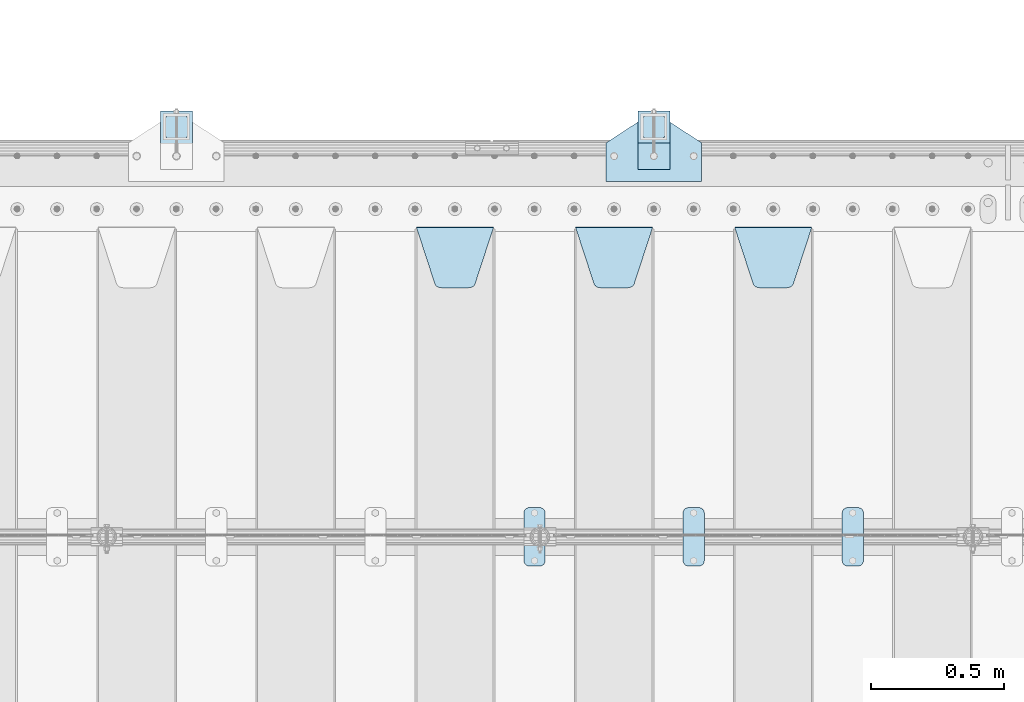
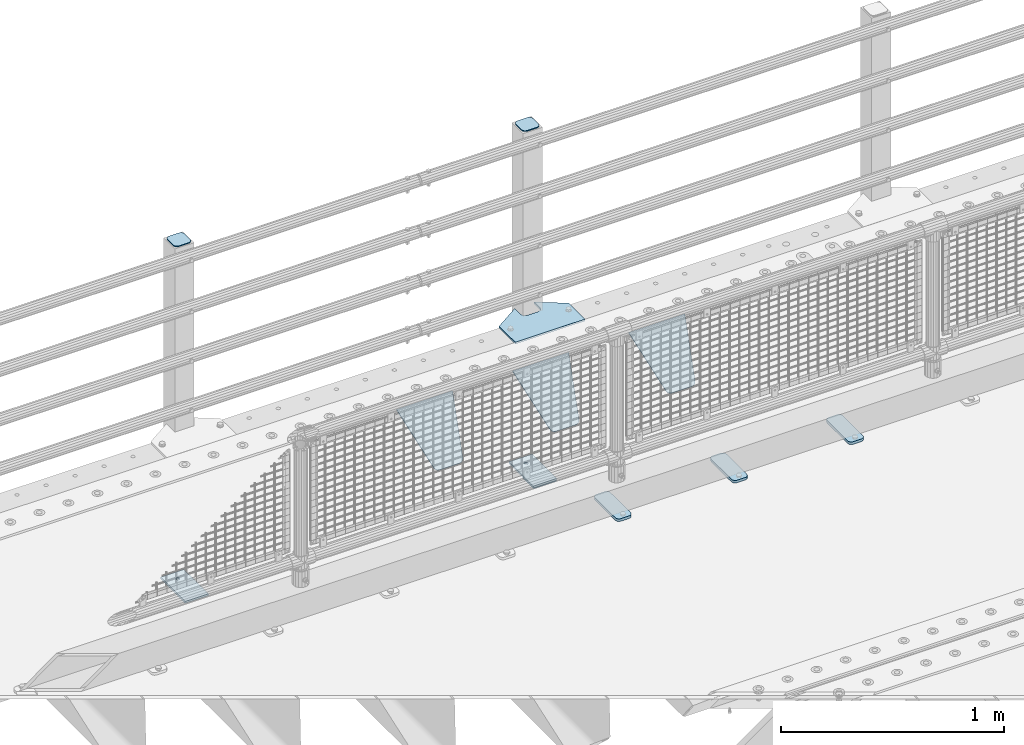
# One storey, part 233 of 270: 12 plates.
"""IFC2X3 building model written with IfcOpenShell, lengths in millimetres."""

from ifc_helpers import new_model, si_unit, frame, origin_with_axes, place, context, subcontext, project, spatial, faceted_brep, material, type_object, element, save


model = new_model("IFC2X3")

# Units and contexts
model_context = context("Model", 3, precision=1e-05, world=origin_with_axes())
body_context = subcontext(model_context, "Body", "Model", "MODEL_VIEW")
ifc_project = project(units=[si_unit("LENGTHUNIT", "METRE", prefix="MILLI"), si_unit("AREAUNIT", "SQUARE_METRE"), si_unit("VOLUMEUNIT", "CUBIC_METRE"), si_unit("MASSUNIT", "GRAM", prefix="KILO"), si_unit("TIMEUNIT", "SECOND"), si_unit("PLANEANGLEUNIT", "RADIAN"), si_unit("SOLIDANGLEUNIT", "STERADIAN"), si_unit("THERMODYNAMICTEMPERATUREUNIT", "DEGREE_CELSIUS"), si_unit("LUMINOUSINTENSITYUNIT", "LUMEN")], contexts=[model_context])

# Site, building, storey
site_placement = place(None, origin_with_axes())
site = spatial("IfcSite", under=ifc_project, at=site_placement, CompositionType="ELEMENT")
building_placement = place(site_placement, origin_with_axes())
building = spatial("IfcBuilding", under=site, at=building_placement, Name="Standard", CompositionType="ELEMENT")
storey_placement = place(building_placement, origin_with_axes())
storey = spatial("IfcBuildingStorey", under=building, at=storey_placement, Name="Undefined", CompositionType="ELEMENT", Elevation=0.0)

# Plates
ifc_material_1 = material(Name="STEEL/S355J2")
plate_type_1 = type_object("IfcPlateType", PredefinedType="NOTDEFINED")
plate_1_placement = place(storey_placement, frame((5770.0, -14995.0, 5.00000000004911), z_axis=(0.0, 1.0, 0.0), x_axis=(1.0, 0.0, 0.0)))
element("IfcPlate", 1, at=plate_1_placement, inside=storey, type_object=plate_type_1, material=ifc_material_1, context=body_context, shape_type="Brep", body=[
    faceted_brep([(0.0, -5.0, 0.0), (2.31396552408114e-06, -5.0, 145.0), (2.31396552408114e-06, 5.0, 145.0), (0.0, 5.0, 0.0), (130.0, -5.0, 230.0), (130.0, 5.0, 230.0), (130.0, -5.0, 180.0), (130.0, 5.0, 180.0), (130.48036798992, -5.0, 175.122741949597), (130.48036798992, 5.0, 175.122741949597), (131.903011687216, -5.0, 170.432914190873), (131.903011687216, 5.0, 170.432914190873), (134.213259692435, -5.0, 166.11074417451), (134.213259692435, 5.0, 166.11074417451), (137.322330470335, -5.0, 162.322330470337), (137.322330470335, 5.0, 162.322330470337), (141.110744174512, -5.0, 159.213259692437), (141.110744174512, 5.0, 159.213259692437), (145.432914190871, -5.0, 156.903011687218), (145.432914190871, 5.0, 156.903011687218), (150.122741949595, -5.0, 155.48036798992), (150.122741949595, 5.0, 155.48036798992), (155.0, -5.0, 155.0), (155.0, 5.0, 155.0), (205.0, -5.0, 155.0), (205.0, 5.0, 155.0), (209.877258050405, -5.0, 155.48036798992), (209.877258050405, 5.0, 155.48036798992), (214.567085809129, -5.0, 156.903011687218), (214.567085809129, 5.0, 156.903011687218), (218.889255825488, -5.0, 159.213259692437), (218.889255825488, 5.0, 159.213259692437), (222.677669529665, -5.0, 162.322330470337), (222.677669529665, 5.0, 162.322330470337), (225.786740307565, -5.0, 166.11074417451), (225.786740307565, 5.0, 166.11074417451), (228.096988312784, -5.0, 170.432914190873), (228.096988312784, 5.0, 170.432914190873), (229.51963201008, -5.0, 175.122741949597), (229.51963201008, 5.0, 175.122741949597), (230.0, -5.0, 180.0), (230.0, 5.0, 180.0), (230.0, -5.0, 230.0), (230.0, 5.0, 230.0), (360.0, -5.0, 145.0), (360.0, 5.0, 145.0), (360.0, -5.0, -7.27595761418343e-12), (360.0, 5.0, -7.27595761418343e-12)], [[[0, 1, 2, 3]], [[1, 4, 5, 2]], [[4, 6, 7, 5]], [[6, 8, 9, 7]], [[8, 10, 11, 9]], [[10, 12, 13, 11]], [[12, 14, 15, 13]], [[14, 16, 17, 15]], [[16, 18, 19, 17]], [[18, 20, 21, 19]], [[20, 22, 23, 21]], [[22, 24, 25, 23]], [[24, 26, 27, 25]], [[26, 28, 29, 27]], [[28, 30, 31, 29]], [[30, 32, 33, 31]], [[32, 34, 35, 33]], [[34, 36, 37, 35]], [[36, 38, 39, 37]], [[38, 40, 41, 39]], [[40, 42, 43, 41]], [[42, 44, 45, 43]], [[44, 46, 47, 45]], [[46, 0, 3, 47]], [[5, 7, 9, 11, 13, 15, 17, 19, 21, 23, 25, 27, 29, 31, 33, 35, 37, 39, 41, 43, 45, 47, 3, 2]], [[46, 44, 42, 40, 38, 36, 34, 32, 30, 28, 26, 24, 22, 20, 18, 16, 14, 12, 10, 8, 6, 4, 1, 0]]]),
])
plate_type_2 = type_object("IfcPlateType", PredefinedType="NOTDEFINED")
for number, where, z_axis, x_axis in (
    (2, (5890.00000000014, -14949.9999999998, -850.000000000002), (0.0, 1.0, 0.0), (1.0, 0.0, 0.0)),
    (3, (4090.00000000014, -14949.9999999998, -850.000000000002), (0.0, 1.0, 0.0), (1.0, 0.0, 0.0)),
):
    element("IfcPlate", number, at=place(storey_placement, frame(where, z_axis=z_axis, x_axis=x_axis)), inside=storey, type_object=plate_type_2, material=ifc_material_1, context=body_context, shape_type="Brep", body=[
        faceted_brep([(66.3639610305399, -5.0, 163.636038969114), (66.3639610305399, 5.0, 163.636038969114), (59.9999999998618, 5.0, 160.999999999793), (59.9999999998618, -5.0, 160.999999999793), (53.6360389691836, 5.0, 163.636038969114), (53.6360389691836, -5.0, 163.636038969114), (50.9999999998618, 5.0, 169.999999999793), (50.9999999998618, -5.0, 169.999999999793), (53.6360389691836, 5.0, 176.363961030471), (53.6360389691836, -5.0, 176.363961030471), (59.9999999998618, 5.0, 178.999999999793), (59.9999999998618, -5.0, 178.999999999793), (66.3639610305399, 5.0, 176.363961030471), (66.3639610305399, -5.0, 176.363961030471), (68.9999999998618, 5.0, 169.999999999793), (68.9999999998618, -5.0, 169.999999999793), (120.0, -5.0, 0.0), (120.0, -5.0, 220.0), (0.0, -5.0, 220.0), (0.0, -5.0, 0.0), (0.0, 5.0, 0.0), (120.0, 5.0, 0.0), (120.0, 5.0, 220.0), (0.0, 5.0, 220.0)], [[[0, 1, 2, 3]], [[3, 2, 4, 5]], [[5, 4, 6, 7]], [[7, 6, 8, 9]], [[9, 8, 10, 11]], [[11, 10, 12, 13]], [[13, 12, 14, 15]], [[15, 14, 1, 0]], [[16, 17, 18, 19], [3, 5, 7, 9, 11, 13, 15, 0]], [[16, 19, 20, 21]], [[17, 16, 21, 22]], [[18, 17, 22, 23]], [[19, 18, 23, 20]], [[22, 21, 20, 23], [10, 8, 6, 4, 2, 1, 14, 12]]]),
    ])
plate_type_3 = type_object("IfcPlateType", PredefinedType="NOTDEFINED")
plate_2_placement = place(storey_placement, frame((5994.00000000013, -14833.9999999998, 1012.50000000001), z_axis=(0.0, 1.0, 0.0), x_axis=(-1.0, 0.0, 0.0)))
element("IfcPlate", 4, at=plate_2_placement, inside=storey, type_object=plate_type_3, material=ifc_material_1, context=body_context, shape_type="Brep", body=[
    faceted_brep([(0.0, -2.5, 19.0), (0.0, -2.5, 69.0), (0.0, 2.5, 69.0), (0.0, 2.5, 19.0), (0.476369668544066, -2.5, 73.2278977451697), (0.476369668544066, 2.5, 73.2278977451697), (1.88159150985302, -2.5, 77.2437910432327), (1.88159150985302, 2.5, 77.2437910432327), (4.14520183310742, -2.5, 80.8463062353167), (4.14520183310742, 2.5, 80.8463062353167), (7.15369376468516, -2.5, 83.8547981668926), (7.15369376468516, 2.5, 83.8547981668926), (10.7562089567655, -2.5, 86.1184084901452), (10.7562089567655, 2.5, 86.1184084901452), (14.7721022548285, -2.5, 87.5236303314541), (14.7721022548285, 2.5, 87.5236303314541), (19.0, -2.5, 88.0), (19.0, 2.5, 88.0), (69.0, -2.5, 88.0), (69.0, 2.5, 88.0), (73.2278977451715, -2.5, 87.5236303314541), (73.2278977451715, 2.5, 87.5236303314541), (77.2437910432345, -2.5, 86.1184084901452), (77.2437910432345, 2.5, 86.1184084901452), (80.8463062353148, -2.5, 83.8547981668926), (80.8463062353148, 2.5, 83.8547981668926), (83.8547981668926, -2.5, 80.8463062353167), (83.8547981668926, 2.5, 80.8463062353167), (86.118408490147, -2.5, 77.2437910432345), (86.118408490147, 2.5, 77.2437910432345), (87.5236303314559, -2.5, 73.2278977451697), (87.5236303314559, 2.5, 73.2278977451697), (88.0, -2.5, 69.0), (88.0, 2.5, 69.0), (88.0, -2.5, 19.0), (88.0, 2.5, 19.0), (87.5236303314559, -2.5, 14.7721022548303), (87.5236303314559, 2.5, 14.7721022548303), (86.118408490147, -2.5, 10.7562089567673), (86.118408490147, 2.5, 10.7562089567673), (83.8547981668926, -2.5, 7.15369376468334), (83.8547981668926, 2.5, 7.15369376468334), (80.8463062353148, -2.5, 4.14520183310742), (80.8463062353148, 2.5, 4.14520183310742), (77.2437910432345, -2.5, 1.88159150985484), (77.2437910432345, 2.5, 1.88159150985484), (73.2278977451715, -2.5, 0.476369668545885), (73.2278977451715, 2.5, 0.476369668545885), (69.0, -2.5, 0.0), (69.0, 2.5, 0.0), (19.0, -2.5, 0.0), (19.0, 2.5, 0.0), (14.7721022548285, -2.5, 0.476369668545885), (14.7721022548285, 2.5, 0.476369668545885), (10.7562089567655, -2.5, 1.88159150985484), (10.7562089567655, 2.5, 1.88159150985484), (7.15369376468516, -2.5, 4.14520183310742), (7.15369376468516, 2.5, 4.14520183310742), (4.14520183310742, -2.5, 7.15369376468334), (4.14520183310742, 2.5, 7.15369376468334), (1.88159150985302, -2.5, 10.7562089567673), (1.88159150985302, 2.5, 10.7562089567673), (0.476369668544066, -2.5, 14.7721022548303), (0.476369668544066, 2.5, 14.7721022548303)], [[[0, 1, 2, 3]], [[1, 4, 5, 2]], [[4, 6, 7, 5]], [[6, 8, 9, 7]], [[8, 10, 11, 9]], [[10, 12, 13, 11]], [[12, 14, 15, 13]], [[14, 16, 17, 15]], [[16, 18, 19, 17]], [[18, 20, 21, 19]], [[20, 22, 23, 21]], [[22, 24, 25, 23]], [[24, 26, 27, 25]], [[26, 28, 29, 27]], [[28, 30, 31, 29]], [[30, 32, 33, 31]], [[32, 34, 35, 33]], [[34, 36, 37, 35]], [[36, 38, 39, 37]], [[38, 40, 41, 39]], [[40, 42, 43, 41]], [[42, 44, 45, 43]], [[44, 46, 47, 45]], [[46, 48, 49, 47]], [[48, 50, 51, 49]], [[50, 52, 53, 51]], [[52, 54, 55, 53]], [[54, 56, 57, 55]], [[56, 58, 59, 57]], [[58, 60, 61, 59]], [[60, 62, 63, 61]], [[62, 0, 3, 63]], [[5, 7, 9, 11, 13, 15, 17, 19, 21, 23, 25, 27, 29, 31, 33, 35, 37, 39, 41, 43, 45, 47, 49, 51, 53, 55, 57, 59, 61, 63, 3, 2]], [[62, 60, 58, 56, 54, 52, 50, 48, 46, 44, 42, 40, 38, 36, 34, 32, 30, 28, 26, 24, 22, 20, 18, 16, 14, 12, 10, 8, 6, 4, 1, 0]]]),
])
plate_3_placement = place(storey_placement, frame((4194.00000000013, -14833.9999999998, 1012.50000000001), z_axis=(0.0, 1.0, 0.0), x_axis=(-1.0, 0.0, 0.0)))
element("IfcPlate", 5, at=plate_3_placement, inside=storey, type_object=plate_type_3, material=ifc_material_1, context=body_context, shape_type="Brep", body=[
    faceted_brep([(0.0, -2.5, 19.0), (0.0, -2.5, 69.0), (0.0, 2.5, 69.0), (0.0, 2.5, 19.0), (0.476369668544066, -2.5, 73.2278977451697), (0.476369668544066, 2.5, 73.2278977451697), (1.88159150985302, -2.5, 77.2437910432327), (1.88159150985302, 2.5, 77.2437910432327), (4.14520183310742, -2.5, 80.8463062353167), (4.14520183310742, 2.5, 80.8463062353167), (7.15369376468516, -2.5, 83.8547981668926), (7.15369376468516, 2.5, 83.8547981668926), (10.7562089567655, -2.5, 86.1184084901452), (10.7562089567655, 2.5, 86.1184084901452), (14.7721022548285, -2.5, 87.5236303314541), (14.7721022548285, 2.5, 87.5236303314541), (19.0, -2.5, 88.0), (19.0, 2.5, 88.0), (69.0, -2.5, 88.0), (69.0, 2.5, 88.0), (73.2278977451715, -2.5, 87.5236303314541), (73.2278977451715, 2.5, 87.5236303314541), (77.2437910432345, -2.5, 86.1184084901452), (77.2437910432345, 2.5, 86.1184084901452), (80.8463062353148, -2.5, 83.8547981668926), (80.8463062353148, 2.5, 83.8547981668926), (83.8547981668926, -2.5, 80.8463062353167), (83.8547981668926, 2.5, 80.8463062353167), (86.118408490147, -2.5, 77.2437910432345), (86.118408490147, 2.5, 77.2437910432345), (87.5236303314559, -2.5, 73.2278977451697), (87.5236303314559, 2.5, 73.2278977451697), (88.0, -2.5, 69.0), (88.0, 2.5, 69.0), (88.0, -2.5, 19.0), (88.0, 2.5, 19.0), (87.5236303314559, -2.5, 14.7721022548303), (87.5236303314559, 2.5, 14.7721022548303), (86.118408490147, -2.5, 10.7562089567673), (86.118408490147, 2.5, 10.7562089567673), (83.8547981668926, -2.5, 7.15369376468334), (83.8547981668926, 2.5, 7.15369376468334), (80.8463062353148, -2.5, 4.14520183310742), (80.8463062353148, 2.5, 4.14520183310742), (77.2437910432345, -2.5, 1.88159150985484), (77.2437910432345, 2.5, 1.88159150985484), (73.2278977451715, -2.5, 0.476369668545885), (73.2278977451715, 2.5, 0.476369668545885), (69.0, -2.5, 0.0), (69.0, 2.5, 0.0), (19.0, -2.5, 0.0), (19.0, 2.5, 0.0), (14.7721022548285, -2.5, 0.476369668545885), (14.7721022548285, 2.5, 0.476369668545885), (10.7562089567655, -2.5, 1.88159150985484), (10.7562089567655, 2.5, 1.88159150985484), (7.15369376468516, -2.5, 4.14520183310742), (7.15369376468516, 2.5, 4.14520183310742), (4.14520183310742, -2.5, 7.15369376468334), (4.14520183310742, 2.5, 7.15369376468334), (1.88159150985302, -2.5, 10.7562089567673), (1.88159150985302, 2.5, 10.7562089567673), (0.476369668544066, -2.5, 14.7721022548303), (0.476369668544066, 2.5, 14.7721022548303)], [[[0, 1, 2, 3]], [[1, 4, 5, 2]], [[4, 6, 7, 5]], [[6, 8, 9, 7]], [[8, 10, 11, 9]], [[10, 12, 13, 11]], [[12, 14, 15, 13]], [[14, 16, 17, 15]], [[16, 18, 19, 17]], [[18, 20, 21, 19]], [[20, 22, 23, 21]], [[22, 24, 25, 23]], [[24, 26, 27, 25]], [[26, 28, 29, 27]], [[28, 30, 31, 29]], [[30, 32, 33, 31]], [[32, 34, 35, 33]], [[34, 36, 37, 35]], [[36, 38, 39, 37]], [[38, 40, 41, 39]], [[40, 42, 43, 41]], [[42, 44, 45, 43]], [[44, 46, 47, 45]], [[46, 48, 49, 47]], [[48, 50, 51, 49]], [[50, 52, 53, 51]], [[52, 54, 55, 53]], [[54, 56, 57, 55]], [[56, 58, 59, 57]], [[58, 60, 61, 59]], [[60, 62, 63, 61]], [[62, 0, 3, 63]], [[5, 7, 9, 11, 13, 15, 17, 19, 21, 23, 25, 27, 29, 31, 33, 35, 37, 39, 41, 43, 45, 47, 49, 51, 53, 55, 57, 59, 61, 63, 3, 2]], [[62, 60, 58, 56, 54, 52, 50, 48, 46, 44, 42, 40, 38, 36, 34, 32, 30, 28, 26, 24, 22, 20, 18, 16, 14, 12, 10, 8, 6, 4, 1, 0]]]),
])
plate_type_4 = type_object("IfcPlateType", PredefinedType="NOTDEFINED")
plate_4_placement = place(storey_placement, frame((5890.00000000014, -14949.9999999998, -857.500000000002), z_axis=(0.0, 1.0, 0.0), x_axis=(1.0, 0.0, 0.0)))
element("IfcPlate", 6, at=plate_4_placement, inside=storey, type_object=plate_type_4, material=ifc_material_1, context=body_context, shape_type="Brep", body=[
    faceted_brep([(0.0, -2.5, 0.0), (0.0, -2.5, 100.0), (0.0, 2.5, 100.0), (0.0, 2.5, 0.0), (120.0, -2.5, 100.0), (120.0, 2.5, 100.0), (120.0, -2.5, 0.0), (120.0, 2.5, 0.0)], [[[0, 1, 2, 3]], [[1, 4, 5, 2]], [[4, 6, 7, 5]], [[6, 0, 3, 7]], [[5, 7, 3, 2]], [[6, 4, 1, 0]]]),
])
plate_type_5 = type_object("IfcPlateType", PredefinedType="NOTDEFINED")
plate_5_placement = place(storey_placement, frame((6660.0, -16225.5, 21.0199999999977), z_axis=(1.0, 0.0, 0.0), x_axis=(0.0, -1.0, 0.0)))
element("IfcPlate", 7, at=plate_5_placement, inside=storey, type_object=plate_type_5, material=ifc_material_1, context=body_context, shape_type="Brep", body=[
    faceted_brep([(0.0, -7.0, 20.0), (0.0, -7.0, 60.0), (0.0, 7.0, 60.0), (0.0, 7.0, 20.0), (0.384294391937146, -7.0, 63.9018064403208), (0.384294391937146, 7.0, 63.9018064403208), (1.52240934977453, -7.0, 67.6536686473009), (1.52240934977453, 7.0, 67.6536686473009), (3.37060775395003, -7.0, 71.1114046603907), (3.37060775395003, 7.0, 71.1114046603907), (5.8578643762703, -7.0, 74.1421356237297), (5.8578643762703, 7.0, 74.1421356237297), (8.88859533960931, -7.0, 76.62939224605), (8.88859533960931, 7.0, 76.62939224605), (12.3463313526991, -7.0, 78.4775906502255), (12.3463313526991, 7.0, 78.4775906502255), (16.0981935596792, -7.0, 79.6157056080629), (16.0981935596792, 7.0, 79.6157056080629), (20.0, -7.0, 80.0), (20.0, 7.0, 80.0), (200.0, -7.0, 80.0), (200.0, 7.0, 80.0), (203.901806440321, -7.0, 79.6157056080629), (203.901806440321, 7.0, 79.6157056080629), (207.653668647301, -7.0, 78.4775906502255), (207.653668647301, 7.0, 78.4775906502255), (211.111404660391, -7.0, 76.62939224605), (211.111404660391, 7.0, 76.62939224605), (214.142135623733, -7.0, 74.1421356237297), (214.142135623733, 7.0, 74.1421356237297), (216.629392246054, -7.0, 71.1114046603907), (216.629392246054, 7.0, 71.1114046603907), (218.477590650225, -7.0, 67.6536686473009), (218.477590650225, 7.0, 67.6536686473009), (219.615705608063, -7.0, 63.9018064403208), (219.615705608063, 7.0, 63.9018064403208), (220.0, -7.0, 60.0), (220.0, 7.0, 60.0), (220.0, -7.0, 20.0), (220.0, 7.0, 20.0), (219.615705608063, -7.0, 16.0981935596792), (219.615705608063, 7.0, 16.0981935596792), (218.477590650225, -7.0, 12.3463313526991), (218.477590650225, 7.0, 12.3463313526991), (216.629392246054, -7.0, 8.88859533960931), (216.629392246054, 7.0, 8.88859533960931), (214.142135623733, -7.0, 5.8578643762703), (214.142135623733, 7.0, 5.8578643762703), (211.111404660391, -7.0, 3.37060775395003), (211.111404660391, 7.0, 3.37060775395003), (207.653668647301, -7.0, 1.52240934977453), (207.653668647301, 7.0, 1.52240934977453), (203.901806440321, -7.0, 0.384294391937146), (203.901806440321, 7.0, 0.384294391937146), (200.0, -7.0, 0.0), (200.0, 7.0, 0.0), (20.0, -7.0, 0.0), (20.0, 7.0, 0.0), (16.0981935596792, -7.0, 0.384294391937146), (16.0981935596792, 7.0, 0.384294391937146), (12.3463313526991, -7.0, 1.52240934977453), (12.3463313526991, 7.0, 1.52240934977453), (8.88859533960931, -7.0, 3.37060775395003), (8.88859533960931, 7.0, 3.37060775395003), (5.8578643762703, -7.0, 5.8578643762703), (5.8578643762703, 7.0, 5.8578643762703), (3.37060775395003, -7.0, 8.88859533960931), (3.37060775395003, 7.0, 8.88859533960931), (1.52240934977453, -7.0, 12.3463313526991), (1.52240934977453, 7.0, 12.3463313526991), (0.384294391937146, -7.0, 16.0981935596792), (0.384294391937146, 7.0, 16.0981935596792)], [[[0, 1, 2, 3]], [[1, 4, 5, 2]], [[4, 6, 7, 5]], [[6, 8, 9, 7]], [[8, 10, 11, 9]], [[10, 12, 13, 11]], [[12, 14, 15, 13]], [[14, 16, 17, 15]], [[16, 18, 19, 17]], [[18, 20, 21, 19]], [[20, 22, 23, 21]], [[22, 24, 25, 23]], [[24, 26, 27, 25]], [[26, 28, 29, 27]], [[28, 30, 31, 29]], [[30, 32, 33, 31]], [[32, 34, 35, 33]], [[34, 36, 37, 35]], [[36, 38, 39, 37]], [[38, 40, 41, 39]], [[40, 42, 43, 41]], [[42, 44, 45, 43]], [[44, 46, 47, 45]], [[46, 48, 49, 47]], [[48, 50, 51, 49]], [[50, 52, 53, 51]], [[52, 54, 55, 53]], [[54, 56, 57, 55]], [[56, 58, 59, 57]], [[58, 60, 61, 59]], [[60, 62, 63, 61]], [[62, 64, 65, 63]], [[64, 66, 67, 65]], [[66, 68, 69, 67]], [[68, 70, 71, 69]], [[70, 0, 3, 71]], [[5, 7, 9, 11, 13, 15, 17, 19, 21, 23, 25, 27, 29, 31, 33, 35, 37, 39, 41, 43, 45, 47, 49, 51, 53, 55, 57, 59, 61, 63, 65, 67, 69, 71, 3, 2]], [[70, 68, 66, 64, 62, 60, 58, 56, 54, 52, 50, 48, 46, 44, 42, 40, 38, 36, 34, 32, 30, 28, 26, 24, 22, 20, 18, 16, 14, 12, 10, 8, 6, 4, 1, 0]]]),
])
plate_6_placement = place(storey_placement, frame((6060.0, -16225.5, 21.0199999999977), z_axis=(1.0, 0.0, 0.0), x_axis=(0.0, -1.0, 0.0)))
element("IfcPlate", 8, at=plate_6_placement, inside=storey, type_object=plate_type_5, material=ifc_material_1, context=body_context, shape_type="Brep", body=[
    faceted_brep([(0.0, -7.0, 20.0), (0.0, -7.0, 60.0), (0.0, 7.0, 60.0), (0.0, 7.0, 20.0), (0.384294391937146, -7.0, 63.9018064403208), (0.384294391937146, 7.0, 63.9018064403208), (1.52240934977453, -7.0, 67.6536686473009), (1.52240934977453, 7.0, 67.6536686473009), (3.37060775395003, -7.0, 71.1114046603907), (3.37060775395003, 7.0, 71.1114046603907), (5.8578643762703, -7.0, 74.1421356237297), (5.8578643762703, 7.0, 74.1421356237297), (8.88859533960931, -7.0, 76.62939224605), (8.88859533960931, 7.0, 76.62939224605), (12.3463313526991, -7.0, 78.4775906502255), (12.3463313526991, 7.0, 78.4775906502255), (16.0981935596792, -7.0, 79.6157056080629), (16.0981935596792, 7.0, 79.6157056080629), (20.0, -7.0, 80.0), (20.0, 7.0, 80.0), (200.0, -7.0, 80.0), (200.0, 7.0, 80.0), (203.901806440321, -7.0, 79.6157056080629), (203.901806440321, 7.0, 79.6157056080629), (207.653668647301, -7.0, 78.4775906502255), (207.653668647301, 7.0, 78.4775906502255), (211.111404660391, -7.0, 76.62939224605), (211.111404660391, 7.0, 76.62939224605), (214.142135623733, -7.0, 74.1421356237297), (214.142135623733, 7.0, 74.1421356237297), (216.629392246054, -7.0, 71.1114046603907), (216.629392246054, 7.0, 71.1114046603907), (218.477590650225, -7.0, 67.6536686473009), (218.477590650225, 7.0, 67.6536686473009), (219.615705608063, -7.0, 63.9018064403208), (219.615705608063, 7.0, 63.9018064403208), (220.0, -7.0, 60.0), (220.0, 7.0, 60.0), (220.0, -7.0, 20.0), (220.0, 7.0, 20.0), (219.615705608063, -7.0, 16.0981935596792), (219.615705608063, 7.0, 16.0981935596792), (218.477590650225, -7.0, 12.3463313526991), (218.477590650225, 7.0, 12.3463313526991), (216.629392246054, -7.0, 8.88859533960931), (216.629392246054, 7.0, 8.88859533960931), (214.142135623733, -7.0, 5.8578643762703), (214.142135623733, 7.0, 5.8578643762703), (211.111404660391, -7.0, 3.37060775395003), (211.111404660391, 7.0, 3.37060775395003), (207.653668647301, -7.0, 1.52240934977453), (207.653668647301, 7.0, 1.52240934977453), (203.901806440321, -7.0, 0.384294391937146), (203.901806440321, 7.0, 0.384294391937146), (200.0, -7.0, 0.0), (200.0, 7.0, 0.0), (20.0, -7.0, 0.0), (20.0, 7.0, 0.0), (16.0981935596792, -7.0, 0.384294391937146), (16.0981935596792, 7.0, 0.384294391937146), (12.3463313526991, -7.0, 1.52240934977453), (12.3463313526991, 7.0, 1.52240934977453), (8.88859533960931, -7.0, 3.37060775395003), (8.88859533960931, 7.0, 3.37060775395003), (5.8578643762703, -7.0, 5.8578643762703), (5.8578643762703, 7.0, 5.8578643762703), (3.37060775395003, -7.0, 8.88859533960931), (3.37060775395003, 7.0, 8.88859533960931), (1.52240934977453, -7.0, 12.3463313526991), (1.52240934977453, 7.0, 12.3463313526991), (0.384294391937146, -7.0, 16.0981935596792), (0.384294391937146, 7.0, 16.0981935596792)], [[[0, 1, 2, 3]], [[1, 4, 5, 2]], [[4, 6, 7, 5]], [[6, 8, 9, 7]], [[8, 10, 11, 9]], [[10, 12, 13, 11]], [[12, 14, 15, 13]], [[14, 16, 17, 15]], [[16, 18, 19, 17]], [[18, 20, 21, 19]], [[20, 22, 23, 21]], [[22, 24, 25, 23]], [[24, 26, 27, 25]], [[26, 28, 29, 27]], [[28, 30, 31, 29]], [[30, 32, 33, 31]], [[32, 34, 35, 33]], [[34, 36, 37, 35]], [[36, 38, 39, 37]], [[38, 40, 41, 39]], [[40, 42, 43, 41]], [[42, 44, 45, 43]], [[44, 46, 47, 45]], [[46, 48, 49, 47]], [[48, 50, 51, 49]], [[50, 52, 53, 51]], [[52, 54, 55, 53]], [[54, 56, 57, 55]], [[56, 58, 59, 57]], [[58, 60, 61, 59]], [[60, 62, 63, 61]], [[62, 64, 65, 63]], [[64, 66, 67, 65]], [[66, 68, 69, 67]], [[68, 70, 71, 69]], [[70, 0, 3, 71]], [[5, 7, 9, 11, 13, 15, 17, 19, 21, 23, 25, 27, 29, 31, 33, 35, 37, 39, 41, 43, 45, 47, 49, 51, 53, 55, 57, 59, 61, 63, 65, 67, 69, 71, 3, 2]], [[70, 68, 66, 64, 62, 60, 58, 56, 54, 52, 50, 48, 46, 44, 42, 40, 38, 36, 34, 32, 30, 28, 26, 24, 22, 20, 18, 16, 14, 12, 10, 8, 6, 4, 1, 0]]]),
])
plate_7_placement = place(storey_placement, frame((5460.0, -16225.5, 21.0199999999977), z_axis=(1.0, 0.0, 0.0), x_axis=(0.0, -1.0, 0.0)))
element("IfcPlate", 9, at=plate_7_placement, inside=storey, type_object=plate_type_5, material=ifc_material_1, context=body_context, shape_type="Brep", body=[
    faceted_brep([(0.0, -7.0, 20.0), (0.0, -7.0, 60.0), (0.0, 7.0, 60.0), (0.0, 7.0, 20.0), (0.384294391937146, -7.0, 63.9018064403208), (0.384294391937146, 7.0, 63.9018064403208), (1.52240934977453, -7.0, 67.6536686473009), (1.52240934977453, 7.0, 67.6536686473009), (3.37060775395003, -7.0, 71.1114046603907), (3.37060775395003, 7.0, 71.1114046603907), (5.8578643762703, -7.0, 74.1421356237297), (5.8578643762703, 7.0, 74.1421356237297), (8.88859533960931, -7.0, 76.62939224605), (8.88859533960931, 7.0, 76.62939224605), (12.3463313526991, -7.0, 78.4775906502255), (12.3463313526991, 7.0, 78.4775906502255), (16.0981935596792, -7.0, 79.6157056080629), (16.0981935596792, 7.0, 79.6157056080629), (20.0, -7.0, 80.0), (20.0, 7.0, 80.0), (200.0, -7.0, 80.0), (200.0, 7.0, 80.0), (203.901806440321, -7.0, 79.6157056080629), (203.901806440321, 7.0, 79.6157056080629), (207.653668647301, -7.0, 78.4775906502255), (207.653668647301, 7.0, 78.4775906502255), (211.111404660391, -7.0, 76.62939224605), (211.111404660391, 7.0, 76.62939224605), (214.142135623733, -7.0, 74.1421356237297), (214.142135623733, 7.0, 74.1421356237297), (216.629392246054, -7.0, 71.1114046603907), (216.629392246054, 7.0, 71.1114046603907), (218.477590650225, -7.0, 67.6536686473009), (218.477590650225, 7.0, 67.6536686473009), (219.615705608063, -7.0, 63.9018064403208), (219.615705608063, 7.0, 63.9018064403208), (220.0, -7.0, 60.0), (220.0, 7.0, 60.0), (220.0, -7.0, 20.0), (220.0, 7.0, 20.0), (219.615705608063, -7.0, 16.0981935596792), (219.615705608063, 7.0, 16.0981935596792), (218.477590650225, -7.0, 12.3463313526991), (218.477590650225, 7.0, 12.3463313526991), (216.629392246054, -7.0, 8.88859533960931), (216.629392246054, 7.0, 8.88859533960931), (214.142135623733, -7.0, 5.8578643762703), (214.142135623733, 7.0, 5.8578643762703), (211.111404660391, -7.0, 3.37060775395003), (211.111404660391, 7.0, 3.37060775395003), (207.653668647301, -7.0, 1.52240934977453), (207.653668647301, 7.0, 1.52240934977453), (203.901806440321, -7.0, 0.384294391937146), (203.901806440321, 7.0, 0.384294391937146), (200.0, -7.0, 0.0), (200.0, 7.0, 0.0), (20.0, -7.0, 0.0), (20.0, 7.0, 0.0), (16.0981935596792, -7.0, 0.384294391937146), (16.0981935596792, 7.0, 0.384294391937146), (12.3463313526991, -7.0, 1.52240934977453), (12.3463313526991, 7.0, 1.52240934977453), (8.88859533960931, -7.0, 3.37060775395003), (8.88859533960931, 7.0, 3.37060775395003), (5.8578643762703, -7.0, 5.8578643762703), (5.8578643762703, 7.0, 5.8578643762703), (3.37060775395003, -7.0, 8.88859533960931), (3.37060775395003, 7.0, 8.88859533960931), (1.52240934977453, -7.0, 12.3463313526991), (1.52240934977453, 7.0, 12.3463313526991), (0.384294391937146, -7.0, 16.0981935596792), (0.384294391937146, 7.0, 16.0981935596792)], [[[0, 1, 2, 3]], [[1, 4, 5, 2]], [[4, 6, 7, 5]], [[6, 8, 9, 7]], [[8, 10, 11, 9]], [[10, 12, 13, 11]], [[12, 14, 15, 13]], [[14, 16, 17, 15]], [[16, 18, 19, 17]], [[18, 20, 21, 19]], [[20, 22, 23, 21]], [[22, 24, 25, 23]], [[24, 26, 27, 25]], [[26, 28, 29, 27]], [[28, 30, 31, 29]], [[30, 32, 33, 31]], [[32, 34, 35, 33]], [[34, 36, 37, 35]], [[36, 38, 39, 37]], [[38, 40, 41, 39]], [[40, 42, 43, 41]], [[42, 44, 45, 43]], [[44, 46, 47, 45]], [[46, 48, 49, 47]], [[48, 50, 51, 49]], [[50, 52, 53, 51]], [[52, 54, 55, 53]], [[54, 56, 57, 55]], [[56, 58, 59, 57]], [[58, 60, 61, 59]], [[60, 62, 63, 61]], [[62, 64, 65, 63]], [[64, 66, 67, 65]], [[66, 68, 69, 67]], [[68, 70, 71, 69]], [[70, 0, 3, 71]], [[5, 7, 9, 11, 13, 15, 17, 19, 21, 23, 25, 27, 29, 31, 33, 35, 37, 39, 41, 43, 45, 47, 49, 51, 53, 55, 57, 59, 61, 63, 65, 67, 69, 71, 3, 2]], [[70, 68, 66, 64, 62, 60, 58, 56, 54, 52, 50, 48, 46, 44, 42, 40, 38, 36, 34, 32, 30, 28, 26, 24, 22, 20, 18, 16, 14, 12, 10, 8, 6, 4, 1, 0]]]),
])
ifc_material_2 = material(Name="STEEL/S355N")
plate_type_6 = type_object("IfcPlateType", PredefinedType="NOTDEFINED")
plate_8_placement = place(storey_placement, frame((6255.0, -15168.2322330441, -1.76776695296576), z_axis=(0.0, -0.707106781186548, -0.707106781186547), x_axis=(1.0, 0.0, 0.0)))
element("IfcPlate", 10, at=plate_8_placement, inside=storey, type_object=plate_type_6, material=ifc_material_2, context=body_context, shape_type="Brep", body=[
    faceted_brep([(0.0, -2.5, 0.0), (69.345504679477, -2.5, 300.171731424831), (69.345504679477, 2.5, 300.171731424831), (0.0, 2.5, 0.0), (70.9274061199576, -2.5, 304.8974424154), (70.9274061199576, 2.5, 304.8974424154), (73.3818627772307, -2.49999999999818, 309.234538108527), (73.3818627772307, 2.50000000000182, 309.234538108527), (76.6187032999551, -2.5, 313.023683126103), (76.6187032999551, 2.5, 313.023683126103), (80.5190132704993, -2.5, 316.125672595372), (80.5190132704993, 2.50000000000182, 316.125672595372), (84.9395038596849, -2.49999999999818, 318.426546230476), (84.9395038596849, 2.5, 318.426546230476), (89.7177759439219, -2.49999999999818, 319.841774983275), (89.7177759439219, 2.50000000000182, 319.841774983275), (94.678286292652, -2.5, 320.319366455078), (94.678286292652, 2.5, 320.319366455078), (195.321713707348, -2.5, 320.319366455078), (195.321713707348, 2.5, 320.319366455078), (200.282224056078, -2.49999999999818, 319.841774983275), (200.282224056078, 2.50000000000182, 319.841774983275), (205.060496140315, -2.5, 318.426546230476), (205.060496140315, 2.5, 318.426546230476), (209.480986729501, -2.5, 316.12567259537), (209.480986729501, 2.50000000000182, 316.12567259537), (213.381296700045, -2.5, 313.023683126103), (213.381296700045, 2.5, 313.023683126103), (216.618137222769, -2.49999999999818, 309.234538108525), (216.618137222769, 2.50000000000182, 309.234538108527), (219.072593880042, -2.49999999999818, 304.897442415398), (219.072593880042, 2.50000000000182, 304.897442415397), (220.654495320523, -2.5, 300.171731424831), (220.654495320523, 2.5, 300.171731424831), (290.0, -2.49999999999818, 0.0), (290.0, 2.5, 0.0)], [[[0, 1, 2, 3]], [[1, 4, 5, 2]], [[4, 6, 7, 5]], [[6, 8, 9, 7]], [[8, 10, 11, 9]], [[10, 12, 13, 11]], [[12, 14, 15, 13]], [[14, 16, 17, 15]], [[16, 18, 19, 17]], [[18, 20, 21, 19]], [[20, 22, 23, 21]], [[22, 24, 25, 23]], [[24, 26, 27, 25]], [[26, 28, 29, 27]], [[28, 30, 31, 29]], [[30, 32, 33, 31]], [[32, 34, 35, 33]], [[34, 0, 3, 35]], [[5, 7, 9, 11, 13, 15, 17, 19, 21, 23, 25, 27, 29, 31, 33, 35, 3, 2]], [[34, 32, 30, 28, 26, 24, 22, 20, 18, 16, 14, 12, 10, 8, 6, 4, 1, 0]]]),
])
plate_9_placement = place(storey_placement, frame((5655.0, -15168.2322330441, -1.76776695296576), z_axis=(0.0, -0.707106781186548, -0.707106781186547), x_axis=(1.0, 0.0, 0.0)))
element("IfcPlate", 11, at=plate_9_placement, inside=storey, type_object=plate_type_6, material=ifc_material_2, context=body_context, shape_type="Brep", body=[
    faceted_brep([(0.0, -2.5, 0.0), (69.345504679477, -2.5, 300.171731424831), (69.345504679477, 2.5, 300.171731424831), (0.0, 2.5, 0.0), (70.9274061199576, -2.5, 304.8974424154), (70.9274061199576, 2.5, 304.8974424154), (73.3818627772307, -2.49999999999818, 309.234538108527), (73.3818627772307, 2.50000000000182, 309.234538108527), (76.6187032999551, -2.5, 313.023683126103), (76.6187032999551, 2.5, 313.023683126103), (80.5190132704993, -2.5, 316.125672595372), (80.5190132704993, 2.50000000000182, 316.125672595372), (84.9395038596849, -2.49999999999818, 318.426546230476), (84.9395038596849, 2.5, 318.426546230476), (89.7177759439219, -2.49999999999818, 319.841774983275), (89.7177759439219, 2.50000000000182, 319.841774983275), (94.678286292652, -2.5, 320.319366455078), (94.678286292652, 2.5, 320.319366455078), (195.321713707348, -2.5, 320.319366455078), (195.321713707348, 2.5, 320.319366455078), (200.282224056078, -2.49999999999818, 319.841774983275), (200.282224056078, 2.50000000000182, 319.841774983275), (205.060496140315, -2.5, 318.426546230476), (205.060496140315, 2.5, 318.426546230476), (209.480986729501, -2.5, 316.12567259537), (209.480986729501, 2.50000000000182, 316.12567259537), (213.381296700045, -2.5, 313.023683126103), (213.381296700045, 2.5, 313.023683126103), (216.618137222769, -2.49999999999818, 309.234538108525), (216.618137222769, 2.50000000000182, 309.234538108527), (219.072593880042, -2.49999999999818, 304.897442415398), (219.072593880042, 2.50000000000182, 304.897442415397), (220.654495320523, -2.5, 300.171731424831), (220.654495320523, 2.5, 300.171731424831), (290.0, -2.49999999999818, 0.0), (290.0, 2.5, 0.0)], [[[0, 1, 2, 3]], [[1, 4, 5, 2]], [[4, 6, 7, 5]], [[6, 8, 9, 7]], [[8, 10, 11, 9]], [[10, 12, 13, 11]], [[12, 14, 15, 13]], [[14, 16, 17, 15]], [[16, 18, 19, 17]], [[18, 20, 21, 19]], [[20, 22, 23, 21]], [[22, 24, 25, 23]], [[24, 26, 27, 25]], [[26, 28, 29, 27]], [[28, 30, 31, 29]], [[30, 32, 33, 31]], [[32, 34, 35, 33]], [[34, 0, 3, 35]], [[5, 7, 9, 11, 13, 15, 17, 19, 21, 23, 25, 27, 29, 31, 33, 35, 3, 2]], [[34, 32, 30, 28, 26, 24, 22, 20, 18, 16, 14, 12, 10, 8, 6, 4, 1, 0]]]),
])
plate_10_placement = place(storey_placement, frame((5055.0, -15168.2322330441, -1.76776695296576), z_axis=(0.0, -0.707106781186548, -0.707106781186547), x_axis=(1.0, 0.0, 0.0)))
element("IfcPlate", 12, at=plate_10_placement, inside=storey, type_object=plate_type_6, material=ifc_material_2, context=body_context, shape_type="Brep", body=[
    faceted_brep([(0.0, -2.5, 0.0), (69.345504679477, -2.5, 300.171731424831), (69.345504679477, 2.5, 300.171731424831), (0.0, 2.5, 0.0), (70.9274061199576, -2.5, 304.8974424154), (70.9274061199576, 2.5, 304.8974424154), (73.3818627772307, -2.49999999999818, 309.234538108527), (73.3818627772307, 2.50000000000182, 309.234538108527), (76.6187032999551, -2.5, 313.023683126103), (76.6187032999551, 2.5, 313.023683126103), (80.5190132704993, -2.5, 316.125672595372), (80.5190132704993, 2.50000000000182, 316.125672595372), (84.9395038596849, -2.49999999999818, 318.426546230476), (84.9395038596849, 2.5, 318.426546230476), (89.7177759439219, -2.49999999999818, 319.841774983275), (89.7177759439219, 2.50000000000182, 319.841774983275), (94.678286292652, -2.5, 320.319366455078), (94.678286292652, 2.5, 320.319366455078), (195.321713707348, -2.5, 320.319366455078), (195.321713707348, 2.5, 320.319366455078), (200.282224056078, -2.49999999999818, 319.841774983275), (200.282224056078, 2.50000000000182, 319.841774983275), (205.060496140315, -2.5, 318.426546230476), (205.060496140315, 2.5, 318.426546230476), (209.480986729501, -2.5, 316.12567259537), (209.480986729501, 2.50000000000182, 316.12567259537), (213.381296700045, -2.5, 313.023683126103), (213.381296700045, 2.5, 313.023683126103), (216.618137222769, -2.49999999999818, 309.234538108525), (216.618137222769, 2.50000000000182, 309.234538108527), (219.072593880042, -2.49999999999818, 304.897442415398), (219.072593880042, 2.50000000000182, 304.897442415397), (220.654495320523, -2.5, 300.171731424831), (220.654495320523, 2.5, 300.171731424831), (290.0, -2.49999999999818, 0.0), (290.0, 2.5, 0.0)], [[[0, 1, 2, 3]], [[1, 4, 5, 2]], [[4, 6, 7, 5]], [[6, 8, 9, 7]], [[8, 10, 11, 9]], [[10, 12, 13, 11]], [[12, 14, 15, 13]], [[14, 16, 17, 15]], [[16, 18, 19, 17]], [[18, 20, 21, 19]], [[20, 22, 23, 21]], [[22, 24, 25, 23]], [[24, 26, 27, 25]], [[26, 28, 29, 27]], [[28, 30, 31, 29]], [[30, 32, 33, 31]], [[32, 34, 35, 33]], [[34, 0, 3, 35]], [[5, 7, 9, 11, 13, 15, 17, 19, 21, 23, 25, 27, 29, 31, 33, 35, 3, 2]], [[34, 32, 30, 28, 26, 24, 22, 20, 18, 16, 14, 12, 10, 8, 6, 4, 1, 0]]]),
])

save(model, "model.ifc")
